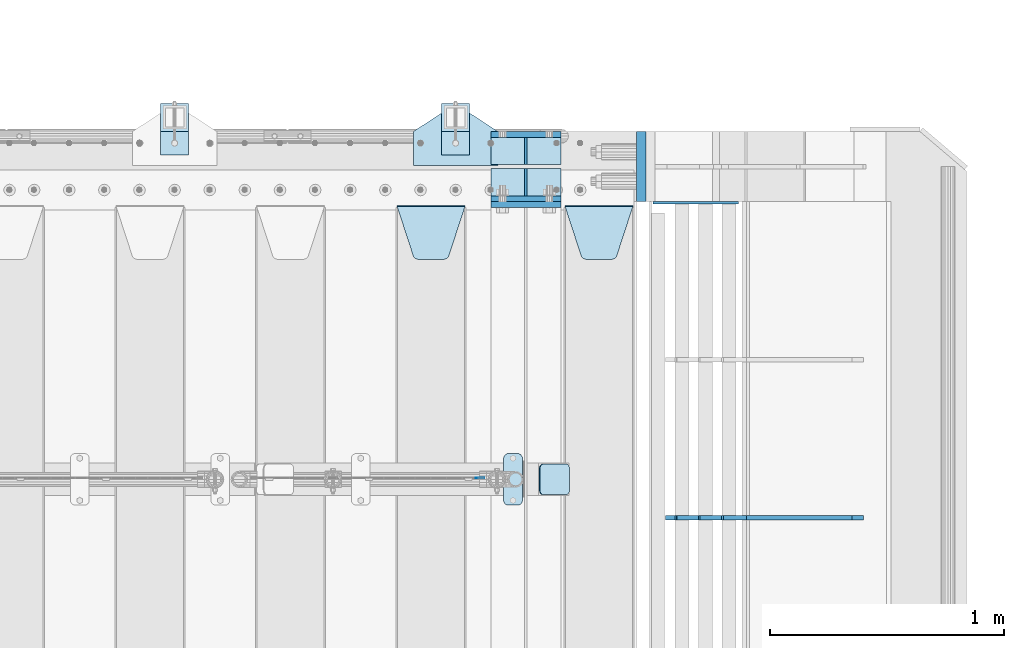
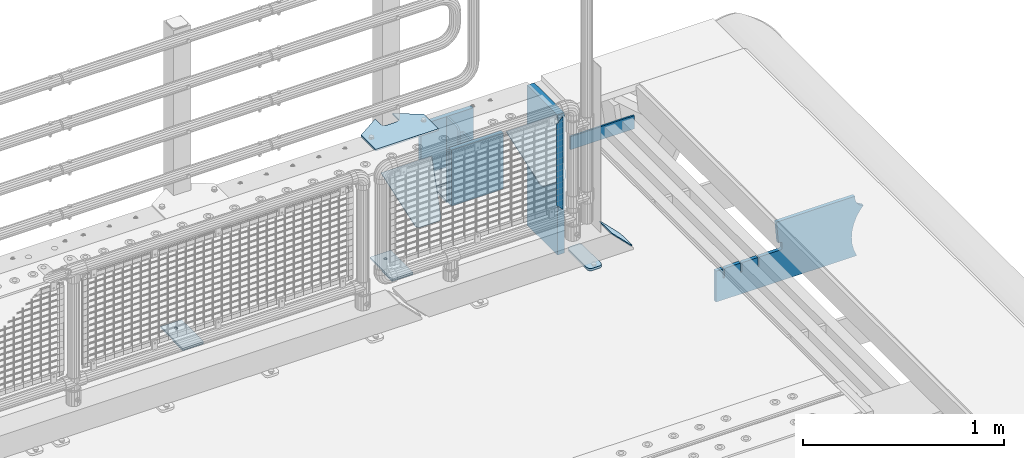
# One storey, part 203 of 219: 20 plates.
"""IFC2X3 building model written with IfcOpenShell, lengths in millimetres."""

from ifc_helpers import new_model, si_unit, frame, origin_with_axes, place, context, subcontext, project, spatial, faceted_brep, material, type_object, element, save


model = new_model("IFC2X3")

# Units and contexts
model_context = context("Model", 3, precision=1e-05, world=origin_with_axes())
body_context = subcontext(model_context, "Body", "Model", "MODEL_VIEW")
ifc_project = project(units=[si_unit("LENGTHUNIT", "METRE", prefix="MILLI"), si_unit("AREAUNIT", "SQUARE_METRE"), si_unit("VOLUMEUNIT", "CUBIC_METRE"), si_unit("MASSUNIT", "GRAM", prefix="KILO"), si_unit("TIMEUNIT", "SECOND"), si_unit("PLANEANGLEUNIT", "RADIAN"), si_unit("SOLIDANGLEUNIT", "STERADIAN"), si_unit("THERMODYNAMICTEMPERATUREUNIT", "DEGREE_CELSIUS"), si_unit("LUMINOUSINTENSITYUNIT", "LUMEN")], contexts=[model_context])

# Site, building, storey
site_placement = place(None, origin_with_axes())
site = spatial("IfcSite", under=ifc_project, at=site_placement, CompositionType="ELEMENT")
building_placement = place(site_placement, origin_with_axes())
building = spatial("IfcBuilding", under=site, at=building_placement, Name="Standard", CompositionType="ELEMENT")
storey_placement = place(building_placement, origin_with_axes())
storey = spatial("IfcBuildingStorey", under=building, at=storey_placement, Name="Undefined", CompositionType="ELEMENT", Elevation=0.0)

# Plates
ifc_material_1 = material(Name="STEEL/S355N")
plate_type_1 = type_object("IfcPlateType", PredefinedType="NOTDEFINED")
for number, where, z_axis, x_axis in (
    (1, (13405.0, 33137.5, -339.999999999995), (0.0, 0.0, 1.0), (1.0, 0.0, 0.0)),
    (2, (13405.0, 32862.5, -339.999999999995), (0.0, 0.0, 1.0), (1.0, 0.0, 0.0)),
):
    element("IfcPlate", number, at=place(storey_placement, frame(where, z_axis=z_axis, x_axis=x_axis)), inside=storey, type_object=plate_type_1, material=ifc_material_1, context=body_context, shape_type="Brep", body=[
        faceted_brep([(0.0, -12.5, 0.0), (0.0, -12.5, 310.0), (0.0, 12.5, 310.0), (0.0, 12.5, 0.0), (300.0, -12.5, 310.0), (300.0, 12.5, 310.0), (300.0, -12.5, 0.0), (300.0, 12.5, 0.0)], [[[0, 1, 2, 3]], [[1, 4, 5, 2]], [[4, 6, 7, 5]], [[6, 0, 3, 7]], [[5, 7, 3, 2]], [[6, 4, 1, 0]]]),
    ])
plate_1_placement = place(storey_placement, frame((13405.0, 32837.5, -340.000000000044), z_axis=(0.0, 0.0, 1.0), x_axis=(1.0, 0.0, 0.0)))
element("IfcPlate", 3, at=plate_1_placement, inside=storey, type_object=plate_type_1, material=ifc_material_1, context=body_context, shape_type="Brep", body=[
    faceted_brep([(0.0, -12.5, 0.0), (9.27684595808387e-10, -12.5, 340.0), (9.27684595808387e-10, 12.5, 340.0), (0.0, 12.5, 0.0), (300.0, -12.5, 340.0), (300.0, 12.5, 340.0), (300.0, -12.5, 0.0), (300.0, 12.5, 0.0)], [[[0, 1, 2, 3]], [[1, 4, 5, 2]], [[4, 6, 7, 5]], [[6, 0, 3, 7]], [[5, 7, 3, 2]], [[6, 4, 1, 0]]]),
])
plate_type_2 = type_object("IfcPlateType", PredefinedType="NOTDEFINED")
for number, where, z_axis, x_axis in (
    (4, (13405.0, 33008.0, -342.999999999995), (0.0, 1.0, 0.0), (1.0, 0.0, 0.0)),
    (5, (13405.0, 32992.0, -342.999999999995), (0.0, -1.0, 0.0), (1.0, 0.0, 0.0)),
):
    element("IfcPlate", number, at=place(storey_placement, frame(where, z_axis=z_axis, x_axis=x_axis)), inside=storey, type_object=plate_type_2, material=ifc_material_1, context=body_context, shape_type="Brep", body=[
        faceted_brep([(0.0, -7.0, 0.0), (0.0, -7.0, 117.0), (0.0, 7.0, 117.0), (0.0, 7.0, 0.0), (300.0, -7.0, 117.0), (300.0, 7.0, 117.0), (300.0, -7.0, 0.0), (300.0, 7.0, 0.0)], [[[0, 1, 2, 3]], [[1, 4, 5, 2]], [[4, 6, 7, 5]], [[6, 0, 3, 7]], [[5, 7, 3, 2]], [[6, 4, 1, 0]]]),
    ])
plate_type_3 = type_object("IfcPlateType", PredefinedType="NOTDEFINED")
for number, where, z_axis, x_axis in (
    (6, (13555.0, 33008.0, -29.9999999999945), (0.0, 0.0, -1.0), (0.0, 1.0, 0.0)),
    (7, (13555.0, 32992.0, -29.9999999999945), (0.0, 0.0, -1.0), (0.0, -1.0, 0.0)),
):
    element("IfcPlate", number, at=place(storey_placement, frame(where, z_axis=z_axis, x_axis=x_axis)), inside=storey, type_object=plate_type_3, material=ifc_material_1, context=body_context, shape_type="Brep", body=[
        faceted_brep([(0.0, -5.0, 30.0), (0.0, -5.0, 306.0), (0.0, 5.0, 306.0), (0.0, 5.0, 30.0), (117.0, -5.0, 306.0), (117.0, 5.0, 306.0), (117.0, -5.0, 0.0), (117.0, 5.0, 0.0), (30.0, -5.0, 0.0), (30.0, 5.0, 0.0), (24.7905546699913, -5.0, 0.455767409633758), (24.7905546699913, 5.0, 0.455767409633758), (19.7393957002278, -5.0, 1.80922137642275), (19.7393957002278, 5.0, 1.80922137642275), (15.0, -5.0, 4.01923788646684), (15.0, 5.0, 4.01923788646684), (10.7163717094008, -5.0, 7.01866670643066), (10.7163717094008, 5.0, 7.01866670643066), (7.01866670643358, -5.0, 10.7163717094038), (7.01866670643358, 5.0, 10.7163717094038), (4.01923788646673, -5.0, 15.0), (4.01923788646673, 5.0, 15.0), (1.80922137642483, -5.0, 19.7393957002299), (1.80922137642483, 5.0, 19.7393957002299), (0.455767409635882, -5.0, 24.7905546699921), (0.455767409635882, 5.0, 24.7905546699921)], [[[0, 1, 2, 3]], [[1, 4, 5, 2]], [[4, 6, 7, 5]], [[6, 8, 9, 7]], [[8, 10, 11, 9]], [[10, 12, 13, 11]], [[12, 14, 15, 13]], [[14, 16, 17, 15]], [[16, 18, 19, 17]], [[18, 20, 21, 19]], [[20, 22, 23, 21]], [[22, 24, 25, 23]], [[24, 0, 3, 25]], [[5, 7, 9, 11, 13, 15, 17, 19, 21, 23, 25, 3, 2]], [[24, 22, 20, 18, 16, 14, 12, 10, 8, 6, 4, 1, 0]]]),
    ])
plate_type_4 = type_object("IfcPlateType", PredefinedType="NOTDEFINED")
plate_2_placement = place(storey_placement, frame((13722.0, 32831.767766956, -1.76776695296758), z_axis=(0.0, -0.707106781186547, -0.707106781186548), x_axis=(1.0, 0.0, 0.0)))
element("IfcPlate", 8, at=plate_2_placement, inside=storey, type_object=plate_type_4, material=ifc_material_1, context=body_context, shape_type="Brep", body=[
    faceted_brep([(0.0, -2.5, 0.0), (69.345504679477, -2.5, 300.171731424834), (69.345504679477, 2.49999999999636, 300.171731424831), (0.0, 2.5, 0.0), (70.9274061199576, -2.50000000000364, 304.8974424154), (70.9274061199576, 2.49999999999636, 304.8974424154), (73.3818627772307, -2.50000000000364, 309.234538108532), (73.3818627772307, 2.49999999999636, 309.234538108532), (76.6187032999569, -2.50000000000364, 313.023683126106), (76.6187032999569, 2.49999999999636, 313.023683126106), (80.5190132704993, -2.50000000000364, 316.125672595372), (80.5190132704993, 2.49999999999636, 316.125672595372), (84.9395038596831, -2.50000000000364, 318.426546230476), (84.9395038596831, 2.5, 318.426546230479), (89.7177759439237, -2.50000000000364, 319.841774983277), (89.7177759439237, 2.5, 319.841774983281), (94.6782862926502, -2.50000000000364, 320.319366455078), (94.6782862926502, 2.49999999999636, 320.319366455078), (195.32171370735, -2.50000000000364, 320.319366455078), (195.32171370735, 2.49999999999636, 320.319366455078), (200.282224056076, -2.50000000000364, 319.841774983277), (200.282224056076, 2.5, 319.841774983281), (205.060496140317, -2.50000000000364, 318.426546230476), (205.060496140317, 2.49999999999636, 318.426546230476), (209.480986729501, -2.50000000000364, 316.125672595372), (209.480986729501, 2.49999999999636, 316.125672595372), (213.381296700043, -2.50000000000364, 313.023683126106), (213.381296700043, 2.49999999999272, 313.023683126106), (216.618137222769, -2.50000000000364, 309.234538108529), (216.618137222769, 2.49999999999636, 309.234538108525), (219.072593880042, -2.50000000000364, 304.8974424154), (219.072593880042, 2.49999999999636, 304.8974424154), (220.654495320523, -2.5, 300.171731424834), (220.654495320523, 2.49999999999636, 300.171731424831), (290.0, -2.50000000000364, 3.63797880709171e-12), (290.0, 2.49999999999636, 0.0)], [[[0, 1, 2, 3]], [[1, 4, 5, 2]], [[4, 6, 7, 5]], [[6, 8, 9, 7]], [[8, 10, 11, 9]], [[10, 12, 13, 11]], [[12, 14, 15, 13]], [[14, 16, 17, 15]], [[16, 18, 19, 17]], [[18, 20, 21, 19]], [[20, 22, 23, 21]], [[22, 24, 25, 23]], [[24, 26, 27, 25]], [[26, 28, 29, 27]], [[28, 30, 31, 29]], [[30, 32, 33, 31]], [[32, 34, 35, 33]], [[34, 0, 3, 35]], [[5, 7, 9, 11, 13, 15, 17, 19, 21, 23, 25, 27, 29, 31, 33, 35, 3, 2]], [[34, 32, 30, 28, 26, 24, 22, 20, 18, 16, 14, 12, 10, 8, 6, 4, 1, 0]]]),
])
plate_3_placement = place(storey_placement, frame((13005.0, 32831.767766956, -1.76776695296758), z_axis=(0.0, -0.707106781186547, -0.707106781186548), x_axis=(1.0, 0.0, 0.0)))
element("IfcPlate", 9, at=plate_3_placement, inside=storey, type_object=plate_type_4, material=ifc_material_1, context=body_context, shape_type="Brep", body=[
    faceted_brep([(0.0, -2.5, 0.0), (69.345504679477, -2.5, 300.171731424834), (69.345504679477, 2.49999999999636, 300.171731424831), (0.0, 2.5, 0.0), (70.9274061199576, -2.50000000000364, 304.8974424154), (70.9274061199576, 2.49999999999636, 304.8974424154), (73.3818627772307, -2.50000000000364, 309.234538108532), (73.3818627772307, 2.49999999999636, 309.234538108532), (76.6187032999569, -2.50000000000364, 313.023683126106), (76.6187032999569, 2.49999999999636, 313.023683126106), (80.5190132704993, -2.50000000000364, 316.125672595372), (80.5190132704993, 2.49999999999636, 316.125672595372), (84.9395038596831, -2.50000000000364, 318.426546230476), (84.9395038596831, 2.5, 318.426546230479), (89.7177759439237, -2.50000000000364, 319.841774983277), (89.7177759439237, 2.5, 319.841774983281), (94.6782862926502, -2.50000000000364, 320.319366455078), (94.6782862926502, 2.49999999999636, 320.319366455078), (195.32171370735, -2.50000000000364, 320.319366455078), (195.32171370735, 2.49999999999636, 320.319366455078), (200.282224056076, -2.50000000000364, 319.841774983277), (200.282224056076, 2.5, 319.841774983281), (205.060496140317, -2.50000000000364, 318.426546230476), (205.060496140317, 2.49999999999636, 318.426546230476), (209.480986729501, -2.50000000000364, 316.125672595372), (209.480986729501, 2.49999999999636, 316.125672595372), (213.381296700043, -2.50000000000364, 313.023683126106), (213.381296700043, 2.49999999999272, 313.023683126106), (216.618137222769, -2.50000000000364, 309.234538108529), (216.618137222769, 2.49999999999636, 309.234538108525), (219.072593880042, -2.50000000000364, 304.8974424154), (219.072593880042, 2.49999999999636, 304.8974424154), (220.654495320523, -2.5, 300.171731424834), (220.654495320523, 2.49999999999636, 300.171731424831), (290.0, -2.50000000000364, 3.63797880709171e-12), (290.0, 2.49999999999636, 0.0)], [[[0, 1, 2, 3]], [[1, 4, 5, 2]], [[4, 6, 7, 5]], [[6, 8, 9, 7]], [[8, 10, 11, 9]], [[10, 12, 13, 11]], [[12, 14, 15, 13]], [[14, 16, 17, 15]], [[16, 18, 19, 17]], [[18, 20, 21, 19]], [[20, 22, 23, 21]], [[22, 24, 25, 23]], [[24, 26, 27, 25]], [[26, 28, 29, 27]], [[28, 30, 31, 29]], [[30, 32, 33, 31]], [[32, 34, 35, 33]], [[34, 0, 3, 35]], [[5, 7, 9, 11, 13, 15, 17, 19, 21, 23, 25, 27, 29, 31, 33, 35, 3, 2]], [[34, 32, 30, 28, 26, 24, 22, 20, 18, 16, 14, 12, 10, 8, 6, 4, 1, 0]]]),
])
ifc_material_2 = material(Name="Misc_Undefined")
plate_type_5 = type_object("IfcPlateType", PredefinedType="NOTDEFINED")
plate_4_placement = place(storey_placement, frame((13376.4999999862, 31670.4997788013, 914.461469028502), z_axis=(0.706514791587333, 1.30000007553929e-08, -0.707698275586642), x_axis=(-0.707698275586649, 0.0, -0.706514791587326)))
element("IfcPlate", 10, at=plate_4_placement, inside=storey, type_object=plate_type_5, material=ifc_material_2, context=body_context, shape_type="Brep", body=[
    faceted_brep([(0.0, -1.5, -5.6843418860808e-14), (397.726470947267, -1.50000000000364, 398.392700195314), (397.726470947267, 1.49999999999636, 398.392700195314), (0.0, 1.5, -5.6843418860808e-14), (397.767883300783, -1.5, 348.895263671879), (397.767883300783, 1.5, 348.895263671875), (49.4561042785626, -1.5, -4.91127138957381e-11), (49.4561042785626, 1.5, -4.91127138957381e-11)], [[[0, 1, 2, 3]], [[1, 4, 5, 2]], [[4, 6, 7, 5]], [[6, 0, 3, 7]], [[5, 7, 3, 2]], [[6, 4, 1, 0]]]),
])
ifc_material_3 = material()
plate_type_6 = type_object("IfcPlateType", PredefinedType="NOTDEFINED")
plate_5_placement = place(storey_placement, frame((14047.0, 33150.0, -870.0), z_axis=(0.0, 0.0, 1.0), x_axis=(0.0, -1.0, 0.0)))
element("IfcPlate", 11, at=plate_5_placement, inside=storey, type_object=plate_type_6, material=ifc_material_3, context=body_context, shape_type="Brep", body=[
    faceted_brep([(0.0, -20.0, 0.0), (0.0, -20.0, 850.0), (0.0, 20.0, 850.0), (0.0, 20.0, 0.0), (300.0, -20.0, 850.0), (300.0, 20.0, 850.0), (300.0, -20.0, -1.81898940354586e-12), (300.0, 20.0, -1.81898940354586e-12)], [[[0, 1, 2, 3]], [[1, 4, 5, 2]], [[4, 6, 7, 5]], [[6, 0, 3, 7]], [[5, 7, 3, 2]], [[6, 4, 1, 0]]]),
])
ifc_material_4 = material(Name="STEEL/S355J2")
plate_type_7 = type_object("IfcPlateType", PredefinedType="NOTDEFINED")
plate_6_placement = place(storey_placement, frame((13460.0, 31774.5, 21.0199999999977), z_axis=(1.0, 0.0, 0.0), x_axis=(0.0, -1.0, 0.0)))
element("IfcPlate", 12, at=plate_6_placement, inside=storey, type_object=plate_type_7, material=ifc_material_4, context=body_context, shape_type="Brep", body=[
    faceted_brep([(0.0, -7.0, 20.0), (0.0, -7.0, 60.0), (0.0, 7.0, 60.0), (0.0, 7.0, 20.0), (0.384294391937146, -7.0, 63.9018064403226), (0.384294391937146, 7.0, 63.9018064403226), (1.52240934977453, -7.0, 67.6536686473009), (1.52240934977453, 7.0, 67.6536686473009), (3.37060775395003, -7.0, 71.1114046603925), (3.37060775395003, 7.0, 71.1114046603925), (5.8578643762703, -7.0, 74.1421356237315), (5.8578643762703, 7.0, 74.1421356237315), (8.88859533960931, -7.0, 76.6293922460518), (8.88859533960931, 7.0, 76.6293922460518), (12.3463313526991, -7.0, 78.4775906502255), (12.3463313526991, 7.0, 78.4775906502255), (16.0981935596792, -7.0, 79.6157056080647), (16.0981935596792, 7.0, 79.6157056080647), (20.0, -7.0, 80.0), (20.0, 7.0, 80.0), (200.0, -7.0, 80.0), (200.0, 7.0, 80.0), (203.901806440321, -7.0, 79.6157056080647), (203.901806440321, 7.0, 79.6157056080647), (207.653668647301, -7.0, 78.4775906502255), (207.653668647301, 7.0, 78.4775906502255), (211.111404660391, -7.0, 76.6293922460518), (211.111404660391, 7.0, 76.6293922460518), (214.14213562373, -7.0, 74.1421356237315), (214.14213562373, 7.0, 74.1421356237315), (216.62939224605, -7.0, 71.1114046603925), (216.62939224605, 7.0, 71.1114046603925), (218.477590650225, -7.0, 67.6536686473009), (218.477590650225, 7.0, 67.6536686473009), (219.615705608063, -7.0, 63.9018064403226), (219.615705608063, 7.0, 63.9018064403226), (220.0, -7.0, 60.0), (220.0, 7.0, 60.0), (220.0, -7.0, 20.0), (220.0, 7.0, 20.0), (219.615705608063, -7.0, 16.0981935596774), (219.615705608063, 7.0, 16.0981935596774), (218.477590650225, -7.0, 12.3463313526991), (218.477590650225, 7.0, 12.3463313526991), (216.62939224605, -7.0, 8.88859533960749), (216.62939224605, 7.0, 8.88859533960749), (214.14213562373, -7.0, 5.85786437626848), (214.14213562373, 7.0, 5.85786437626848), (211.111404660391, -7.0, 3.37060775394821), (211.111404660391, 7.0, 3.37060775394821), (207.653668647301, -7.0, 1.52240934977453), (207.653668647301, 7.0, 1.52240934977453), (203.901806440321, -7.0, 0.384294391935327), (203.901806440321, 7.0, 0.384294391935327), (200.0, -7.0, 0.0), (200.0, 7.0, 0.0), (20.0, -7.0, 0.0), (20.0, 7.0, 0.0), (16.0981935596792, -7.0, 0.384294391935327), (16.0981935596792, 7.0, 0.384294391935327), (12.3463313526991, -7.0, 1.52240934977453), (12.3463313526991, 7.0, 1.52240934977453), (8.88859533960931, -7.0, 3.37060775394821), (8.88859533960931, 7.0, 3.37060775394821), (5.8578643762703, -7.0, 5.85786437626848), (5.8578643762703, 7.0, 5.85786437626848), (3.37060775395003, -7.0, 8.88859533960749), (3.37060775395003, 7.0, 8.88859533960749), (1.52240934977453, -7.0, 12.3463313526991), (1.52240934977453, 7.0, 12.3463313526991), (0.384294391937146, -7.0, 16.0981935596774), (0.384294391937146, 7.0, 16.0981935596774)], [[[0, 1, 2, 3]], [[1, 4, 5, 2]], [[4, 6, 7, 5]], [[6, 8, 9, 7]], [[8, 10, 11, 9]], [[10, 12, 13, 11]], [[12, 14, 15, 13]], [[14, 16, 17, 15]], [[16, 18, 19, 17]], [[18, 20, 21, 19]], [[20, 22, 23, 21]], [[22, 24, 25, 23]], [[24, 26, 27, 25]], [[26, 28, 29, 27]], [[28, 30, 31, 29]], [[30, 32, 33, 31]], [[32, 34, 35, 33]], [[34, 36, 37, 35]], [[36, 38, 39, 37]], [[38, 40, 41, 39]], [[40, 42, 43, 41]], [[42, 44, 45, 43]], [[44, 46, 47, 45]], [[46, 48, 49, 47]], [[48, 50, 51, 49]], [[50, 52, 53, 51]], [[52, 54, 55, 53]], [[54, 56, 57, 55]], [[56, 58, 59, 57]], [[58, 60, 61, 59]], [[60, 62, 63, 61]], [[62, 64, 65, 63]], [[64, 66, 67, 65]], [[66, 68, 69, 67]], [[68, 70, 71, 69]], [[70, 0, 3, 71]], [[5, 7, 9, 11, 13, 15, 17, 19, 21, 23, 25, 27, 29, 31, 33, 35, 37, 39, 41, 43, 45, 47, 49, 51, 53, 55, 57, 59, 61, 63, 65, 67, 69, 71, 3, 2]], [[70, 68, 66, 64, 62, 60, 58, 56, 54, 52, 50, 48, 46, 44, 42, 40, 38, 36, 34, 32, 30, 28, 26, 24, 22, 20, 18, 16, 14, 12, 10, 8, 6, 4, 1, 0]]]),
])
plate_type_8 = type_object("IfcPlateType", PredefinedType="NOTDEFINED")
plate_7_placement = place(storey_placement, frame((13613.1924184789, 31729.5, 166.254400376661), z_axis=(0.707410512925778, 0.0, -0.706802918925841), x_axis=(0.0, -1.0, 0.0)))
element("IfcPlate", 13, at=plate_7_placement, inside=storey, type_object=plate_type_8, material=ifc_material_4, context=body_context, shape_type="Brep", body=[
    faceted_brep([(0.0, -2.5, 20.0), (0.0, -2.5, 158.926651000977), (0.0, 2.5, 158.926651000977), (0.0, 2.49999999999818, 20.0), (0.384294391937146, -2.5, 162.828457441299), (0.384294391937146, 2.5, 162.828457441299), (1.52240934977453, -2.5, 166.580319648279), (1.52240934977453, 2.5, 166.580319648279), (3.37060775395003, -2.5, 170.038055661367), (3.37060775395003, 2.5, 170.038055661367), (5.8578643762703, -2.5, 173.068786624706), (5.8578643762703, 2.5, 173.068786624706), (8.88859533960931, -2.5, 175.556043247028), (8.88859533960931, 2.5, 175.556043247027), (12.3463313526991, -2.49999999999818, 177.404241651202), (12.3463313526991, 2.5, 177.404241651202), (16.0981935596792, -2.5, 178.542356609041), (16.0981935596792, 2.5, 178.542356609041), (20.0, -2.5, 178.926651000977), (20.0, 2.5, 178.926651000975), (110.0, -2.5, 178.926651000977), (110.0, 2.5, 178.926651000975), (113.901806440321, -2.5, 178.542356609041), (113.901806440321, 2.5, 178.542356609041), (117.653668647301, -2.49999999999818, 177.404241651202), (117.653668647301, 2.5, 177.404241651202), (121.111404660391, -2.5, 175.556043247028), (121.111404660391, 2.5, 175.556043247027), (124.14213562373, -2.5, 173.068786624706), (124.14213562373, 2.5, 173.068786624706), (126.62939224605, -2.5, 170.038055661367), (126.62939224605, 2.5, 170.038055661367), (128.477590650225, -2.5, 166.580319648279), (128.477590650225, 2.5, 166.580319648279), (129.615705608063, -2.5, 162.828457441299), (129.615705608063, 2.5, 162.828457441299), (130.0, -2.5, 158.926651000977), (130.0, 2.5, 158.926651000977), (130.0, -2.5, 20.0), (130.0, 2.49999999999818, 20.0), (129.615705608063, -2.50000000000182, 16.0981935596774), (129.615705608063, 2.50000000000182, 16.0981935596774), (128.477590650225, -2.5, 12.3463313526972), (128.477590650225, 2.5, 12.3463313526991), (126.62939224605, -2.5, 8.88859533960749), (126.62939224605, 2.50000000000182, 8.88859533960749), (124.14213562373, -2.50000000000182, 5.85786437626848), (124.14213562373, 2.5, 5.85786437626848), (121.111404660391, -2.5, 3.37060775394821), (121.111404660391, 2.5, 3.37060775395003), (117.653668647301, -2.5, 1.52240934977453), (117.653668647301, 2.5, 1.52240934977272), (113.901806440321, -2.5, 0.384294391935327), (113.901806440321, 2.5, 0.384294391935327), (110.0, -2.5, -1.81898940354586e-12), (110.0, 2.49999999999818, 0.0), (20.0, -2.5, -1.81898940354586e-12), (20.0, 2.49999999999818, 0.0), (16.0981935596792, -2.5, 0.384294391935327), (16.0981935596792, 2.5, 0.384294391935327), (12.3463313526991, -2.5, 1.52240934977453), (12.3463313526991, 2.5, 1.52240934977272), (8.88859533960931, -2.5, 3.37060775394821), (8.88859533960931, 2.5, 3.37060775395003), (5.8578643762703, -2.50000000000182, 5.85786437626848), (5.8578643762703, 2.5, 5.85786437626848), (3.37060775395003, -2.5, 8.88859533960749), (3.37060775395003, 2.50000000000182, 8.88859533960749), (1.52240934977453, -2.5, 12.3463313526972), (1.52240934977453, 2.5, 12.3463313526991), (0.384294391937146, -2.50000000000182, 16.0981935596774), (0.384294391937146, 2.50000000000182, 16.0981935596774)], [[[0, 1, 2, 3]], [[1, 4, 5, 2]], [[4, 6, 7, 5]], [[6, 8, 9, 7]], [[8, 10, 11, 9]], [[10, 12, 13, 11]], [[12, 14, 15, 13]], [[14, 16, 17, 15]], [[16, 18, 19, 17]], [[18, 20, 21, 19]], [[20, 22, 23, 21]], [[22, 24, 25, 23]], [[24, 26, 27, 25]], [[26, 28, 29, 27]], [[28, 30, 31, 29]], [[30, 32, 33, 31]], [[32, 34, 35, 33]], [[34, 36, 37, 35]], [[36, 38, 39, 37]], [[38, 40, 41, 39]], [[40, 42, 43, 41]], [[42, 44, 45, 43]], [[44, 46, 47, 45]], [[46, 48, 49, 47]], [[48, 50, 51, 49]], [[50, 52, 53, 51]], [[52, 54, 55, 53]], [[54, 56, 57, 55]], [[56, 58, 59, 57]], [[58, 60, 61, 59]], [[60, 62, 63, 61]], [[62, 64, 65, 63]], [[64, 66, 67, 65]], [[66, 68, 69, 67]], [[68, 70, 71, 69]], [[70, 0, 3, 71]], [[5, 7, 9, 11, 13, 15, 17, 19, 21, 23, 25, 27, 29, 31, 33, 35, 37, 39, 41, 43, 45, 47, 49, 51, 53, 55, 57, 59, 61, 63, 65, 67, 69, 71, 3, 2]], [[70, 68, 66, 64, 62, 60, 58, 56, 54, 52, 50, 48, 46, 44, 42, 40, 38, 36, 34, 32, 30, 28, 26, 24, 22, 20, 18, 16, 14, 12, 10, 8, 6, 4, 1, 0]]]),
])
plate_type_9 = type_object("IfcPlateType", PredefinedType="NOTDEFINED")
plate_8_placement = place(storey_placement, frame((13075.0, 33005.0, 5.00000000004911), z_axis=(0.0, 1.0, 0.0), x_axis=(1.0, 0.0, 0.0)))
element("IfcPlate", 14, at=plate_8_placement, inside=storey, type_object=plate_type_9, material=ifc_material_4, context=body_context, shape_type="Brep", body=[
    faceted_brep([(0.0, -5.0, 0.0), (2.31396552408114e-06, -5.0, 145.0), (2.31396552408114e-06, 5.0, 145.0), (0.0, 5.0, 0.0), (130.0, -5.0, 230.0), (130.0, 5.0, 230.0), (130.0, -5.0, 180.0), (130.0, 5.0, 180.0), (130.48036798992, -5.0, 175.122741949599), (130.48036798992, 5.0, 175.122741949599), (131.903011687218, -5.0, 170.432914190875), (131.903011687218, 5.0, 170.432914190875), (134.213259692437, -5.0, 166.110744174512), (134.213259692437, 5.0, 166.110744174512), (137.322330470337, -5.0, 162.322330470335), (137.322330470337, 5.0, 162.322330470335), (141.11074417451, -5.0, 159.213259692435), (141.11074417451, 5.0, 159.213259692435), (145.432914190873, -5.0, 156.903011687216), (145.432914190873, 5.0, 156.903011687216), (150.122741949597, -5.0, 155.48036798992), (150.122741949597, 5.0, 155.48036798992), (155.0, -5.0, 155.0), (155.0, 5.0, 155.0), (205.0, -5.0, 155.0), (205.0, 5.0, 155.0), (209.877258050403, -5.0, 155.48036798992), (209.877258050403, 5.0, 155.48036798992), (214.567085809127, -5.0, 156.903011687216), (214.567085809127, 5.0, 156.903011687216), (218.88925582549, -5.0, 159.213259692435), (218.88925582549, 5.0, 159.213259692435), (222.677669529663, -5.0, 162.322330470335), (222.677669529663, 5.0, 162.322330470335), (225.786740307563, -5.0, 166.110744174512), (225.786740307563, 5.0, 166.110744174512), (228.096988312782, -5.0, 170.432914190875), (228.096988312782, 5.0, 170.432914190875), (229.51963201008, -5.0, 175.122741949599), (229.51963201008, 5.0, 175.122741949599), (230.0, -5.0, 180.0), (230.0, 5.0, 180.0), (230.0, -5.0, 230.0), (230.0, 5.0, 230.0), (360.0, -5.0, 145.0), (360.0, 5.0, 145.0), (360.0, -5.0, -7.27595761418343e-12), (360.0, 5.0, -7.27595761418343e-12)], [[[0, 1, 2, 3]], [[1, 4, 5, 2]], [[4, 6, 7, 5]], [[6, 8, 9, 7]], [[8, 10, 11, 9]], [[10, 12, 13, 11]], [[12, 14, 15, 13]], [[14, 16, 17, 15]], [[16, 18, 19, 17]], [[18, 20, 21, 19]], [[20, 22, 23, 21]], [[22, 24, 25, 23]], [[24, 26, 27, 25]], [[26, 28, 29, 27]], [[28, 30, 31, 29]], [[30, 32, 33, 31]], [[32, 34, 35, 33]], [[34, 36, 37, 35]], [[36, 38, 39, 37]], [[38, 40, 41, 39]], [[40, 42, 43, 41]], [[42, 44, 45, 43]], [[44, 46, 47, 45]], [[46, 0, 3, 47]], [[5, 7, 9, 11, 13, 15, 17, 19, 21, 23, 25, 27, 29, 31, 33, 35, 37, 39, 41, 43, 45, 47, 3, 2]], [[46, 44, 42, 40, 38, 36, 34, 32, 30, 28, 26, 24, 22, 20, 18, 16, 14, 12, 10, 8, 6, 4, 1, 0]]]),
])
plate_type_10 = type_object("IfcPlateType", PredefinedType="NOTDEFINED")
for number, where, z_axis, x_axis in (
    (15, (13195.0000000001, 33050.0000000002, -850.000000000002), (0.0, 1.0, 0.0), (1.0, 0.0, 0.0)),
    (16, (11995.0000000001, 33050.0000000002, -850.000000000002), (0.0, 1.0, 0.0), (1.0, 0.0, 0.0)),
):
    element("IfcPlate", number, at=place(storey_placement, frame(where, z_axis=z_axis, x_axis=x_axis)), inside=storey, type_object=plate_type_10, material=ifc_material_4, context=body_context, shape_type="Brep", body=[
        faceted_brep([(66.3639610305399, -5.0, 163.636038969111), (66.3639610305399, 5.0, 163.636038969111), (59.9999999998618, 5.0, 160.999999999789), (59.9999999998618, -5.0, 160.999999999789), (53.6360389691836, 5.0, 163.636038969111), (53.6360389691836, -5.0, 163.636038969111), (50.9999999998618, 5.0, 169.999999999789), (50.9999999998618, -5.0, 169.999999999789), (53.6360389691836, 5.0, 176.363961030467), (53.6360389691836, -5.0, 176.363961030467), (59.9999999998618, 5.0, 178.999999999789), (59.9999999998618, -5.0, 178.999999999789), (66.3639610305399, 5.0, 176.363961030467), (66.3639610305399, -5.0, 176.363961030467), (68.9999999998618, 5.0, 169.999999999789), (68.9999999998618, -5.0, 169.999999999789), (120.0, -5.0, 0.0), (120.0, -5.0, 220.0), (0.0, -5.0, 220.0), (0.0, -5.0, 0.0), (0.0, 5.0, 0.0), (120.0, 5.0, 0.0), (120.0, 5.0, 220.0), (0.0, 5.0, 220.0)], [[[0, 1, 2, 3]], [[3, 2, 4, 5]], [[5, 4, 6, 7]], [[7, 6, 8, 9]], [[9, 8, 10, 11]], [[11, 10, 12, 13]], [[13, 12, 14, 15]], [[15, 14, 1, 0]], [[16, 17, 18, 19], [3, 5, 7, 9, 11, 13, 15, 0]], [[16, 19, 20, 21]], [[17, 16, 21, 22]], [[18, 17, 22, 23]], [[19, 18, 23, 20]], [[22, 21, 20, 23], [10, 8, 6, 4, 2, 1, 14, 12]]]),
    ])
plate_type_11 = type_object("IfcPlateType", PredefinedType="NOTDEFINED")
for number, where, z_axis, x_axis in (
    (17, (13195.0000000001, 33050.0000000002, -857.500000000002), (0.0, 1.0, 0.0), (1.0, 0.0, 0.0)),
    (18, (11995.0000000001, 33050.0000000002, -857.500000000002), (0.0, 1.0, 0.0), (1.0, 0.0, 0.0)),
):
    element("IfcPlate", number, at=place(storey_placement, frame(where, z_axis=z_axis, x_axis=x_axis)), inside=storey, type_object=plate_type_11, material=ifc_material_4, context=body_context, shape_type="Brep", body=[
        faceted_brep([(0.0, -2.5, 0.0), (0.0, -2.5, 100.0), (0.0, 2.5, 100.0), (0.0, 2.5, 0.0), (120.0, -2.5, 100.0), (120.0, 2.5, 100.0), (120.0, -2.5, 0.0), (120.0, 2.5, 0.0)], [[[0, 1, 2, 3]], [[1, 4, 5, 2]], [[4, 6, 7, 5]], [[6, 0, 3, 7]], [[5, 7, 3, 2]], [[6, 4, 1, 0]]]),
    ])
plate_type_12 = type_object("IfcPlateType", PredefinedType="NOTDEFINED")
plate_9_placement = place(storey_placement, frame((14992.9182339676, 31499.9992828369, -374.002067436516), z_axis=(0.0, 0.0, 1.0), x_axis=(-1.0, 0.0, 0.0)))
element("IfcPlate", 19, at=plate_9_placement, inside=storey, type_object=plate_type_12, material=ifc_material_1, context=body_context, shape_type="Brep", body=[
    faceted_brep([(801.919404066546, -10.0, 188.0), (801.919404066546, 10.0, 188.0), (801.919404066546, 10.0, 132.002067436952), (801.919404066546, -9.99999999999636, 132.002067436952), (793.919404066546, 10.0, 132.002067436952), (793.919404066546, -9.99999999999636, 132.002067436952), (793.919404066546, 10.0, 180.002067436952), (793.919404066546, -10.0, 180.002067436952), (793.527856196908, 10.0, 182.474203391951), (793.527856196908, -10.0, 182.474203391951), (792.391540021546, 10.0, 184.704349455291), (792.391540021546, -10.0, 184.704349455291), (790.621686084885, 10.0, 186.474203391951), (790.621686084885, -10.0, 186.474203391951), (788.391540021546, 10.0, 187.610519567313), (788.391540021546, -10.0, 187.610519567313), (785.919404066546, -10.0, 188.002067436952), (785.919404066546, 10.0, 188.0), (841.0, -10.0, 188.0), (841.0, -10.0, 0.0), (841.0, 10.0, 0.0), (841.0, 10.0, 188.0), (33.3619566736033, -10.0, 0.0), (33.3619566736033, 10.0, 0.0), (36.2350612208174, -10.0, 4.68848050267013), (36.2350612208174, 10.0, 4.68848050267013), (51.487759215941, -10.0, 41.5117508652784), (51.487759215941, 10.0, 41.5117508652784), (60.792242588137, -10.0, 80.2677133162964), (60.792242588137, 10.0, 80.2677133162964), (63.9194040769726, -10.0, 120.002067436515), (63.9194040769726, 10.0, 120.002067436515), (60.792242588137, -10.0, 159.736421556734), (60.792242588137, 10.0, 159.736421556734), (51.487759215941, -10.0, 198.492384007752), (51.487759215941, 10.0, 198.492384007752), (36.2350612208174, -10.0, 235.31565437036), (36.2350612208174, 10.0, 235.31565437036), (15.4097206482093, -10.0, 269.299521518803), (15.4097206482093, 10.0, 269.299521518803), (-3.35474438098936, -10.0, 291.269887256574), (-3.35474438098936, 10.0, 291.269887256574), (-2.36881039375294, -10.0, 291.426043859339), (-2.36881039375294, 10.0, 291.426043859339), (17.1449676604734, -10.0, 301.368810393754), (17.1449676604734, 10.0, 301.368810393754), (32.6311896062471, -10.0, 316.855032339527), (32.6311896062471, 10.0, 316.855032339527), (42.5739561406608, -10.0, 336.368810393754), (42.5739561406608, 10.0, 336.368810393754), (46.0, -10.0, 358.0), (46.0, 10.0, 358.0), (45.0495205499192, -10.0, 364.001091067617), (45.0495205499192, 10.0, 364.001091067617), (495.040008544922, -10.0, 364.010009765625), (495.040008544922, 10.0, 364.010009765625), (483.600036621094, -10.0, 233.759994506836), (483.600036621094, 10.0, 233.759994506836), (472.0, -10.0, 233.759994506836), (472.0, 10.0, 233.759994506836), (468.909830056251, -10.0, 233.270559669787), (468.909830056251, 10.0, 233.270559669787), (466.122147477075, -10.0, 231.850164450585), (466.122147477075, 10.0, 231.850164450585), (463.909830056251, -10.0, 229.637847029761), (463.909830056251, 10.0, 229.637847029761), (462.489434837049, -10.0, 226.850164450585), (462.489434837049, 10.0, 226.850164450585), (462.0, -10.0, 223.759994506836), (462.0, 10.0, 223.759994506836), (462.0, -10.0, 198.0), (462.0, 10.0, 198.0), (462.489434837049, -10.0, 194.909830056251), (462.489434837049, 10.0, 194.909830056251), (463.909830056251, -10.0, 192.122147477075), (463.909830056251, 10.0, 192.122147477075), (466.122147477075, -10.0, 189.909830056251), (466.122147477075, 10.0, 189.909830056251), (468.909830056251, -10.0, 188.489434837048), (468.909830056251, 10.0, 188.489434837048), (472.0, -10.0, 188.0), (472.0, 10.0, 188.0), (585.919404066546, -10.0, 188.002067436952), (585.919404066546, 10.0, 188.0), (588.391540021546, -10.0, 187.610519567313), (588.391540021546, 10.0, 187.610519567313), (590.621686084885, -10.0, 186.474203391951), (590.621686084885, 10.0, 186.474203391951), (592.391540021546, -10.0, 184.704349455291), (592.391540021546, 10.0, 184.704349455291), (593.527856196908, -10.0, 182.474203391951), (593.527856196908, 10.0, 182.474203391951), (593.919404066546, -10.0, 180.002067436952), (593.919404066546, 10.0, 180.002067436952), (593.919404066546, -10.0, 132.002067436952), (593.919404066546, 10.0, 132.002067436952), (601.919404066546, -10.0, 132.002067436952), (601.919404066546, 10.0, 132.002067436952), (601.919404066546, -10.0, 188.0), (601.919404066546, 10.0, 188.0), (685.919404066546, -10.0, 188.002067436952), (685.919404066546, 10.0, 188.0), (688.391540021546, -10.0, 187.610519567313), (688.391540021546, 10.0, 187.610519567313), (690.621686084885, -10.0, 186.474203391951), (690.621686084885, 10.0, 186.474203391951), (692.391540021546, -10.0, 184.704349455291), (692.391540021546, 10.0, 184.704349455291), (693.527856196908, -10.0, 182.474203391951), (693.527856196908, 10.0, 182.474203391951), (693.919404066546, -10.0, 180.002067436952), (693.919404066546, 10.0, 180.002067436952), (693.919404066546, -10.0, 132.002067436952), (693.919404066546, 10.0, 132.002067436952), (701.919404066546, -10.0, 132.002067436952), (701.919404066546, 10.0, 132.002067436952), (701.919404066546, -10.0, 188.0), (701.919404066546, 10.0, 188.0)], [[[0, 1, 2, 3]], [[3, 2, 4, 5]], [[5, 4, 6, 7]], [[7, 6, 8, 9]], [[9, 8, 10, 11]], [[11, 10, 12, 13]], [[13, 12, 14, 15]], [[16, 15, 14, 17]], [[18, 19, 20, 21]], [[20, 19, 22, 23]], [[22, 24, 25, 23]], [[26, 27, 25, 24]], [[28, 29, 27, 26]], [[30, 31, 29, 28]], [[32, 33, 31, 30]], [[34, 35, 33, 32]], [[36, 37, 35, 34]], [[38, 39, 37, 36]], [[39, 38, 40, 41]], [[40, 42, 43, 41]], [[44, 45, 43, 42]], [[46, 47, 45, 44]], [[48, 49, 47, 46]], [[50, 51, 49, 48]], [[52, 53, 51, 50]], [[54, 55, 53, 52]], [[54, 56, 57, 55]], [[56, 58, 59, 57]], [[58, 60, 61, 59]], [[60, 62, 63, 61]], [[62, 64, 65, 63]], [[64, 66, 67, 65]], [[66, 68, 69, 67]], [[68, 70, 71, 69]], [[70, 72, 73, 71]], [[72, 74, 75, 73]], [[74, 76, 77, 75]], [[76, 78, 79, 77]], [[78, 80, 81, 79]], [[81, 80, 82, 83]], [[82, 84, 85, 83]], [[86, 87, 85, 84]], [[88, 89, 87, 86]], [[90, 91, 89, 88]], [[92, 93, 91, 90]], [[94, 95, 93, 92]], [[96, 97, 95, 94]], [[98, 99, 97, 96]], [[99, 98, 100, 101]], [[100, 102, 103, 101]], [[104, 105, 103, 102]], [[106, 107, 105, 104]], [[108, 109, 107, 106]], [[110, 111, 109, 108]], [[112, 113, 111, 110]], [[114, 115, 113, 112]], [[116, 117, 115, 114]], [[117, 116, 16, 17]], [[12, 10, 8, 6, 4, 2, 1, 21, 20, 23, 25, 27, 29, 31, 33, 35, 37, 39, 41, 43, 45, 47, 49, 51, 53, 55, 57, 59, 61, 63, 65, 67, 69, 71, 73, 75, 77, 79, 81, 83, 85, 87, 89, 91, 93, 95, 97, 99, 101, 103, 105, 107, 109, 111, 113, 115, 117, 17, 14]], [[18, 21, 1, 0]], [[116, 114, 112, 110, 108, 106, 104, 102, 100, 98, 96, 94, 92, 90, 88, 86, 84, 82, 80, 78, 76, 74, 72, 70, 68, 66, 64, 62, 60, 58, 56, 54, 52, 50, 48, 46, 44, 42, 40, 38, 36, 34, 32, 30, 28, 26, 24, 22, 19, 18, 0, 3, 5, 7, 9, 11, 13, 15, 16]]]),
])
plate_type_13 = type_object("IfcPlateType", PredefinedType="NOTDEFINED")
plate_10_placement = place(storey_placement, frame((14461.998829901, 32844.9999004229, -249.999999999564), z_axis=(-1.0, 0.0, 0.0), x_axis=(0.0, 0.0, 1.0)))
element("IfcPlate", 20, at=plate_10_placement, inside=storey, type_object=plate_type_13, material=ifc_material_1, context=body_context, shape_type="Brep", body=[
    faceted_brep([(0.0, -5.0, 0.0), (0.0, -5.0, 365.0), (0.0, 5.0, 365.0), (0.0, 5.0, 0.0), (80.0, -5.0, 365.0), (80.0, 5.0, 365.0), (80.0, -5.0, 0.0), (80.0, 5.0, 0.0)], [[[0, 1, 2, 3]], [[1, 4, 5, 2]], [[4, 6, 7, 5]], [[6, 0, 3, 7]], [[5, 7, 3, 2]], [[6, 4, 1, 0]]]),
])

save(model, "model.ifc")
